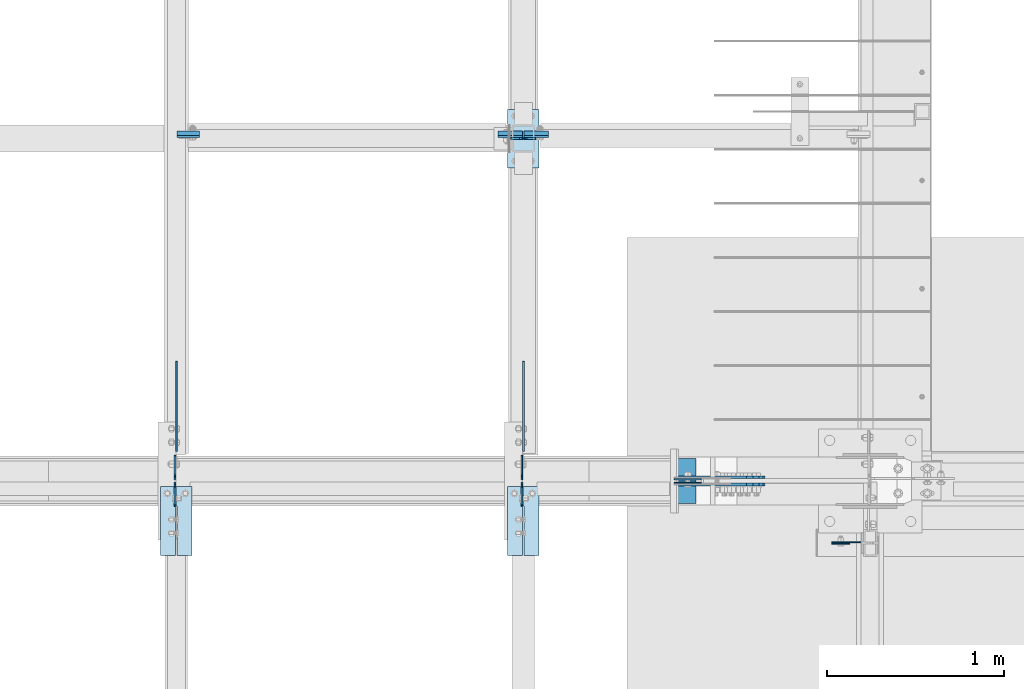
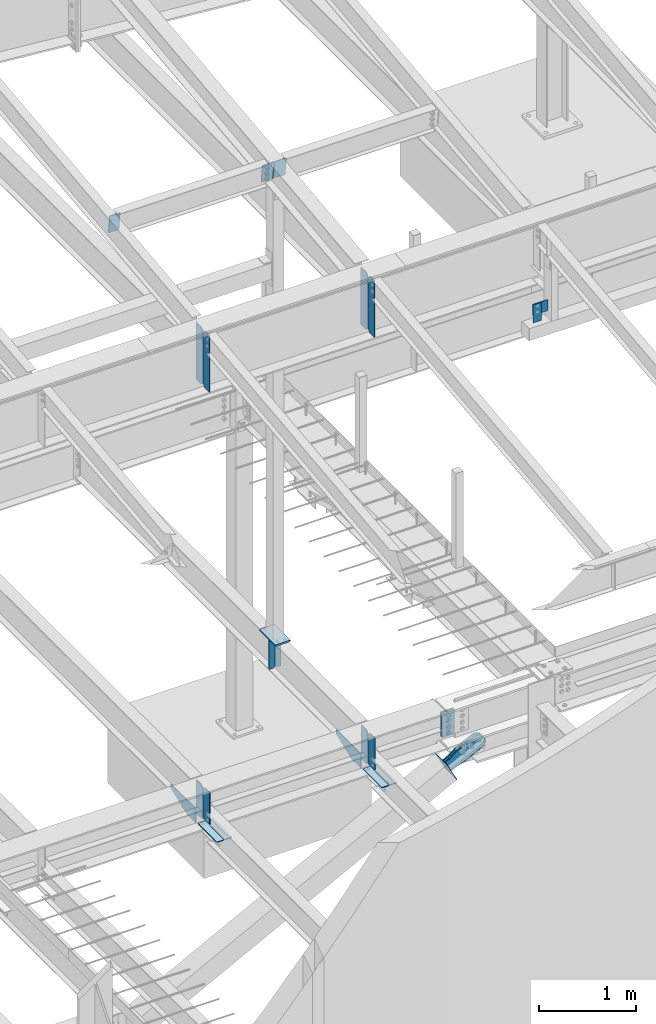
# One storey, part 987 of 1179: 25 plates, 14 elements without a shape of their own.
"""IFC2X3 building model written with IfcOpenShell, lengths in millimetres."""

from ifc_helpers import new_model, si_unit, frame, origin_with_axes, place, context, subcontext, project, spatial, faceted_brep, material, type_object, element, aggregate, save


model = new_model("IFC2X3")

# Units and contexts
model_context = context("Model", 3, precision=1e-05, world=origin_with_axes())
body_context = subcontext(model_context, "Body", "Model", "MODEL_VIEW")
ifc_project = project(units=[si_unit("LENGTHUNIT", "METRE", prefix="MILLI"), si_unit("AREAUNIT", "SQUARE_METRE"), si_unit("VOLUMEUNIT", "CUBIC_METRE"), si_unit("MASSUNIT", "GRAM", prefix="KILO"), si_unit("TIMEUNIT", "SECOND"), si_unit("PLANEANGLEUNIT", "RADIAN"), si_unit("SOLIDANGLEUNIT", "STERADIAN"), si_unit("THERMODYNAMICTEMPERATUREUNIT", "DEGREE_CELSIUS"), si_unit("LUMINOUSINTENSITYUNIT", "LUMEN")], contexts=[model_context])

# Site, building, storey
site_placement = place(None, origin_with_axes())
site = spatial("IfcSite", under=ifc_project, at=site_placement, CompositionType="ELEMENT")
building_placement = place(site_placement, origin_with_axes())
building = spatial("IfcBuilding", under=site, at=building_placement, Name="Undefined", CompositionType="ELEMENT")
storey_placement = place(building_placement, origin_with_axes())
storey = spatial("IfcBuildingStorey", under=building, at=storey_placement, Name="Undefined", CompositionType="ELEMENT", Elevation=0.0)

# Assembly, plates
assembly_1_placement = place(storey_placement, origin_with_axes())
assembly_1 = element("IfcElementAssembly", 1, at=assembly_1_placement, inside=storey, Name="BEAM", AssemblyPlace="NOTDEFINED", PredefinedType="RIGID_FRAME")
ifc_material_1 = material(Name="STEEL/A36")
plate_type_1 = type_object("IfcPlateType", PredefinedType="NOTDEFINED")
plate_1_placement = place(assembly_1_placement, frame((6317.45575008393, 5429.25933465636, 9095.0787842795), z_axis=(0.0, 0.0, 1.0), x_axis=(0.0, -1.0, 0.0)))
plate_1 = element("IfcPlate", 2, at=plate_1_placement, type_object=plate_type_1, material=ifc_material_1, Name="PLATE", context=body_context, shape_type="Brep", body=[
    faceted_brep([(1.81898940354586e-12, -4.76249999999709, 31.75), (0.0, -4.76249999999982, 682.625), (0.0, 4.76249999999982, 682.625), (-1.81898940354586e-12, 4.76249999998981, 31.75), (31.75, -4.76249999999982, 714.375), (31.75, 4.76249999999982, 714.375), (127.0, -4.76249999999982, 714.375), (127.0, 4.76249999999982, 714.375), (127.0, -4.76250000000073, 0.0), (127.0, 4.76250000000073, 0.0), (31.7499999988213, -4.76250000001164, 0.0), (31.7499999988249, 4.76249999998254, 0.0)], [[[0, 1, 2, 3]], [[1, 4, 5, 2]], [[4, 6, 7, 5]], [[6, 8, 9, 7]], [[8, 10, 11, 9]], [[10, 0, 3, 11]], [[5, 7, 9, 11, 3, 2]], [[10, 8, 6, 4, 1, 0]]]),
])
plate_2_placement = place(assembly_1_placement, frame((4361.65575008401, 5429.1855605538, 9095.0787842795), z_axis=(0.0, 0.0, 1.0), x_axis=(0.0, -1.0, 0.0)))
plate_2 = element("IfcPlate", 3, at=plate_2_placement, type_object=plate_type_1, material=ifc_material_1, Name="PLATE", context=body_context, shape_type="Brep", body=[
    faceted_brep([(1.81898940354586e-12, -4.76249999999709, 31.75), (0.0, -4.76249999999982, 682.625), (0.0, 4.76249999999982, 682.625), (-1.81898940354586e-12, 4.76249999998981, 31.75), (31.75, -4.76249999999982, 714.375), (31.75, 4.76249999999982, 714.375), (127.0, -4.76249999999982, 714.375), (127.0, 4.76249999999982, 714.375), (127.0, -4.76250000000073, 0.0), (127.0, 4.76250000000073, 0.0), (31.7499999988213, -4.76250000001164, 0.0), (31.7499999988249, 4.76249999998254, 0.0)], [[[0, 1, 2, 3]], [[1, 4, 5, 2]], [[4, 6, 7, 5]], [[6, 8, 9, 7]], [[8, 10, 11, 9]], [[10, 0, 3, 11]], [[5, 7, 9, 11, 3, 2]], [[10, 8, 6, 4, 1, 0]]]),
])

# Assembly, plate
assembly_2_placement = place(storey_placement, origin_with_axes())
assembly_2 = element("IfcElementAssembly", 4, at=assembly_2_placement, inside=storey, Name="BEAM", AssemblyPlace="NOTDEFINED", PredefinedType="RIGID_FRAME")
plate_3_placement = place(assembly_2_placement, frame((4371.18125, 7377.33420625224, 10042.1704055753), z_axis=(1.0, 0.0, 0.0), x_axis=(0.0, 0.112804359038609, -0.993617218340085)))
plate_3 = element("IfcPlate", 5, at=plate_3_placement, type_object=plate_type_1, material=ifc_material_1, Name="PLATE", context=body_context, shape_type="Brep", body=[
    faceted_brep([(0.0, -4.76249999999709, 0.0), (0.0, -4.76249999999709, 127.0), (0.0, 4.76249999999709, 127.0), (0.0, 4.76249999999709, 0.0), (228.6, -4.76249999999709, 127.0), (228.6, 4.76249999999709, 127.0), (228.6, -4.76249999999709, 0.0), (228.6, 4.76249999999709, 0.0)], [[[0, 1, 2, 3]], [[1, 4, 5, 2]], [[4, 6, 7, 5]], [[6, 0, 3, 7]], [[5, 7, 3, 2]], [[6, 4, 1, 0]]]),
])
aggregate(assembly_2, [plate_3])

assembly_3_placement = place(storey_placement, origin_with_axes())
assembly_3 = element("IfcElementAssembly", 6, at=assembly_3_placement, inside=storey, Name="COLUMN", AssemblyPlace="NOTDEFINED", PredefinedType="RIGID_FRAME")
plate_type_2 = type_object("IfcPlateType", PredefinedType="NOTDEFINED")
plate_4_placement = place(assembly_3_placement, frame((8064.5, 5089.525, 9029.7), z_axis=(1.0, 0.0, 0.0), x_axis=(0.0, 0.0, -1.0)))
plate_4 = element("IfcPlate", 7, at=plate_4_placement, type_object=plate_type_2, material=ifc_material_1, Name="PLATE", context=body_context, shape_type="Brep", body=[
    faceted_brep([(0.0, -3.17500000000109, 0.0), (0.0, -3.17500000000018, 177.800000000003), (0.0, 3.17500000000018, 177.800000000003), (0.0, 3.17500000000109, 7.27595761418343e-12), (139.699996948242, -3.17500000000018, 177.800000000003), (139.699996948242, 3.17500000000018, 177.800000000003), (139.699996948242, -3.17500000000018, 0.0), (139.699996948242, 3.17500000000018, 0.0)], [[[0, 1, 2, 3]], [[1, 4, 5, 2]], [[4, 6, 7, 5]], [[6, 0, 3, 7]], [[5, 7, 3, 2]], [[6, 4, 1, 0]]]),
])
aggregate(assembly_3, [plate_4])

assembly_4_placement = place(storey_placement, origin_with_axes())
assembly_4 = element("IfcElementAssembly", 8, at=assembly_4_placement, inside=storey, Name="BEAM", AssemblyPlace="NOTDEFINED", PredefinedType="RIGID_FRAME")
plate_type_3 = type_object("IfcPlateType", PredefinedType="NOTDEFINED")
plate_5_placement = place(assembly_4_placement, frame((8064.5, 5083.175, 9029.7), z_axis=(1.0, 0.0, 0.0), x_axis=(0.0, 0.0, -1.0)))
plate_5 = element("IfcPlate", 9, at=plate_5_placement, type_object=plate_type_3, material=ifc_material_1, Name="PLATE", context=body_context, shape_type="Brep", body=[
    faceted_brep([(0.0, -3.17500000000109, 0.0), (0.0, -3.17500000000018, 101.599999999999), (0.0, 3.17500000000018, 101.599999999999), (0.0, 3.17500000000109, 7.27595761418343e-12), (228.6, -3.17500000000018, 101.600000000002), (228.6, 3.17500000000018, 101.600000000002), (228.6, -3.17500000000018, 0.0), (228.6, 3.17500000000018, 0.0)], [[[0, 1, 2, 3]], [[1, 4, 5, 2]], [[4, 6, 7, 5]], [[6, 0, 3, 7]], [[5, 7, 3, 2]], [[6, 4, 1, 0]]]),
])
aggregate(assembly_4, [plate_5])

# Assembly, plates
assembly_5_placement = place(storey_placement, origin_with_axes())
assembly_5 = element("IfcElementAssembly", 10, at=assembly_5_placement, inside=storey, Name="BEAM", AssemblyPlace="NOTDEFINED", PredefinedType="RIGID_FRAME")
plate_type_4 = type_object("IfcPlateType", PredefinedType="NOTDEFINED")
plate_6_placement = place(assembly_5_placement, frame((6394.44996446262, 7366.0, 4090.9875), z_axis=(0.0, 0.0, -1.0), x_axis=(-1.0, 0.0, 0.0)))
plate_6 = element("IfcPlate", 11, at=plate_6_placement, type_object=plate_type_4, material=ifc_material_1, Name="PLATE", context=body_context, shape_type="Brep", body=[
    faceted_brep([(0.0, -4.76249999999709, 0.0), (0.0, -4.76249999999982, 381.0), (0.0, 4.76249999999982, 381.0), (0.0, 4.76249999999709, 0.0), (47.6250007629396, -4.76249999999982, 381.0), (47.6250007629396, 4.76249999999982, 381.0), (66.6750000000002, -4.76249999999982, 361.950000762939), (66.6750000000002, 4.76249999999982, 361.950000762939), (66.6750000000002, -4.76249999999982, 19.0499992370605), (66.6750000000002, 4.76249999999982, 19.0499992370605), (47.625, -4.76249999999527, 1.81898940354586e-12), (47.625, 4.76250000000073, 0.0)], [[[0, 1, 2, 3]], [[1, 4, 5, 2]], [[4, 6, 7, 5]], [[6, 8, 9, 7]], [[8, 10, 11, 9]], [[10, 0, 3, 11]], [[5, 7, 9, 11, 3, 2]], [[10, 8, 6, 4, 1, 0]]]),
])
plate_7_placement = place(assembly_5_placement, frame((6254.74996446262, 7366.0, 4090.9875), z_axis=(0.0, 0.0, -1.0), x_axis=(1.0, 0.0, 0.0)))
plate_7 = element("IfcPlate", 12, at=plate_7_placement, type_object=plate_type_4, material=ifc_material_1, Name="PLATE", context=body_context, shape_type="Brep", body=[
    faceted_brep([(0.0, -4.76249999999709, 0.0), (0.0, -4.76249999999982, 381.0), (0.0, 4.76249999999982, 381.0), (0.0, 4.76249999999709, 0.0), (47.6249315497826, -4.76249999999982, 381.0), (47.6249315497826, 4.76249999999982, 381.0), (66.6749307868431, -4.76249999999982, 361.950000762939), (66.6749307868431, 4.76249999999982, 361.950000762939), (66.6749307868431, -4.76249999999982, 19.0499992370605), (66.6749307868431, 4.76249999999982, 19.0499992370605), (47.6249315497826, -4.76249999999982, 0.0), (47.6249315497826, 4.76249999999982, 0.0)], [[[0, 1, 2, 3]], [[1, 4, 5, 2]], [[4, 6, 7, 5]], [[6, 8, 9, 7]], [[8, 10, 11, 9]], [[10, 0, 3, 11]], [[5, 7, 9, 11, 3, 2]], [[10, 8, 6, 4, 1, 0]]]),
])

assembly_6_placement = place(storey_placement, origin_with_axes())
assembly_6 = element("IfcElementAssembly", 13, at=assembly_6_placement, inside=storey, Name="BEAM", AssemblyPlace="NOTDEFINED", PredefinedType="RIGID_FRAME")
plate_type_5 = type_object("IfcPlateType", PredefinedType="NOTDEFINED")
plate_8_placement = place(assembly_6_placement, frame((4360.86207262984, 5441.95000011429, 3656.0125), z_axis=(0.0, 0.0, 1.0), x_axis=(0.0, 1.0, 0.0)))
plate_8 = element("IfcPlate", 14, at=plate_8_placement, type_object=plate_type_5, material=ifc_material_1, Name="PLATE", context=body_context, shape_type="Brep", body=[
    faceted_brep([(0.0, -4.76250000000073, 25.3999996185303), (9.09494701772928e-13, -4.76250000000073, 400.05000038147), (2.72848410531878e-12, 4.76249999999891, 400.05000038147), (0.0, 4.76250000000073, 25.3999996185303), (25.3999996185312, -4.76250000000709, 425.45), (25.399999618533, 4.76249999999254, 425.45), (134.937500000001, -4.76250000003438, 425.45), (134.937500000003, 4.76249999996526, 425.45), (134.937500000001, -4.76250000003438, 0.0), (134.937500000003, 4.76249999996526, 0.0), (25.3999996185303, -4.76250000000073, 0.0), (25.3999996185303, 4.76250000000073, 0.0)], [[[0, 1, 2, 3]], [[1, 4, 5, 2]], [[4, 6, 7, 5]], [[6, 8, 9, 7]], [[8, 10, 11, 9]], [[10, 0, 3, 11]], [[5, 7, 9, 11, 3, 2]], [[10, 8, 6, 4, 1, 0]]]),
])
plate_9_placement = place(assembly_6_placement, frame((4360.86249259372, 5294.3125, 3683.0), z_axis=(0.0, 0.0, 1.0), x_axis=(0.0, 1.0, 0.0)))
plate_9 = element("IfcPlate", 15, at=plate_9_placement, type_object=plate_type_5, material=ifc_material_1, Name="PLATE", context=body_context, shape_type="Brep", body=[
    faceted_brep([(0.0, -4.76249999999709, 0.0), (9.09494701772928e-13, -4.76250000000073, 400.05000038147), (2.72848410531878e-12, 4.76249999999891, 400.05000038147), (0.0, 4.76249999999709, 0.0), (109.53750038147, -4.76249999999982, 400.049987792969), (109.53750038147, 4.76249999999982, 400.049987792969), (134.9375, -4.76249999999982, 374.649988174438), (134.9375, 4.76249999999982, 374.649988174438), (134.937500000001, -4.76250000003438, 0.0), (134.937500000003, 4.76249999996526, 0.0)], [[[0, 1, 2, 3]], [[1, 4, 5, 2]], [[4, 6, 7, 5]], [[6, 8, 9, 7]], [[8, 0, 3, 9]], [[5, 7, 9, 3, 2]], [[8, 6, 4, 1, 0]]]),
])
plate_10_placement = place(assembly_6_placement, frame((6316.66246107175, 5294.3125001905, 3683.0), z_axis=(0.0, 0.0, 1.0), x_axis=(0.0, 1.0, 0.0)))
plate_10 = element("IfcPlate", 16, at=plate_10_placement, type_object=plate_type_5, material=ifc_material_1, Name="PLATE", context=body_context, shape_type="Brep", body=[
    faceted_brep([(0.0, -4.76249999999709, 0.0), (9.09494701772928e-13, -4.76250000000073, 400.05000038147), (2.72848410531878e-12, 4.76249999999891, 400.05000038147), (0.0, 4.76249999999709, 0.0), (109.53750038147, -4.76249999999982, 400.049987792969), (109.53750038147, 4.76249999999982, 400.049987792969), (134.9375, -4.76249999999982, 374.649988174438), (134.9375, 4.76249999999982, 374.649988174438), (134.937500000001, -4.76250000003438, 0.0), (134.937500000003, 4.76249999996526, 0.0)], [[[0, 1, 2, 3]], [[1, 4, 5, 2]], [[4, 6, 7, 5]], [[6, 8, 9, 7]], [[8, 0, 3, 9]], [[5, 7, 9, 3, 2]], [[8, 6, 4, 1, 0]]]),
])
plate_11_placement = place(assembly_6_placement, frame((6316.66196454654, 5441.95, 3656.0125), z_axis=(0.0, 0.0, 1.0), x_axis=(0.0, 1.0, 0.0)))
plate_11 = element("IfcPlate", 17, at=plate_11_placement, type_object=plate_type_5, material=ifc_material_1, Name="PLATE", context=body_context, shape_type="Brep", body=[
    faceted_brep([(0.0, -4.76250000000073, 25.3999996185303), (9.09494701772928e-13, -4.76250000000073, 400.05000038147), (2.72848410531878e-12, 4.76249999999891, 400.05000038147), (0.0, 4.76250000000073, 25.3999996185303), (25.3999996185312, -4.76250000000709, 425.45), (25.399999618533, 4.76249999999254, 425.45), (134.937500000001, -4.76250000003438, 425.45), (134.937500000003, 4.76249999996526, 425.45), (134.937500000001, -4.76250000003438, 0.0), (134.937500000003, 4.76249999996526, 0.0), (25.3999996185303, -4.76250000000073, 0.0), (25.3999996185303, 4.76250000000073, 0.0)], [[[0, 1, 2, 3]], [[1, 4, 5, 2]], [[4, 6, 7, 5]], [[6, 8, 9, 7]], [[8, 10, 11, 9]], [[10, 0, 3, 11]], [[5, 7, 9, 11, 3, 2]], [[10, 8, 6, 4, 1, 0]]]),
])

# Plate
plate_type_6 = type_object("IfcPlateType", PredefinedType="NOTDEFINED")
plate_12_placement = place(assembly_1_placement, frame((6316.66200008393, 5441.95933465636, 9095.0787842795), z_axis=(0.0, 0.0, 1.0), x_axis=(0.0, 1.0, 0.0)))
plate_12 = element("IfcPlate", 18, at=plate_12_placement, type_object=plate_type_6, material=ifc_material_1, Name="PLATE", context=body_context, shape_type="Brep", body=[
    faceted_brep([(1.81898940354586e-12, -4.76249999999709, 31.75), (0.0, -4.76249999999982, 682.625), (0.0, 4.76249999999982, 682.625), (-1.81898940354586e-12, 4.76249999998981, 31.75), (31.75, -4.76249999999982, 714.375), (31.75, 4.76249999999982, 714.375), (139.7, -4.76249999999982, 714.375), (139.7, 4.76249999999982, 714.375), (139.7, -4.76249999999982, 0.0), (139.7, 4.76249999999982, 0.0), (31.7499999988213, -4.76250000001164, 0.0), (31.7499999988249, 4.76249999998254, 0.0)], [[[0, 1, 2, 3]], [[1, 4, 5, 2]], [[4, 6, 7, 5]], [[6, 8, 9, 7]], [[8, 10, 11, 9]], [[10, 0, 3, 11]], [[5, 7, 9, 11, 3, 2]], [[10, 8, 6, 4, 1, 0]]]),
])

plate_13_placement = place(assembly_1_placement, frame((4361.65575008401, 5441.88573914977, 9095.0787842795), z_axis=(0.0, 0.0, 1.0), x_axis=(0.0, 1.0, 0.0)))
plate_13 = element("IfcPlate", 19, at=plate_13_placement, type_object=plate_type_6, material=ifc_material_1, Name="PLATE", context=body_context, shape_type="Brep", body=[
    faceted_brep([(1.81898940354586e-12, -4.76249999999709, 31.75), (0.0, -4.76249999999982, 682.625), (0.0, 4.76249999999982, 682.625), (-1.81898940354586e-12, 4.76249999998981, 31.75), (31.75, -4.76249999999982, 714.375), (31.75, 4.76249999999982, 714.375), (139.7, -4.76249999999982, 714.375), (139.7, 4.76249999999982, 714.375), (139.7, -4.76249999999982, 0.0), (139.7, 4.76249999999982, 0.0), (31.7499999988213, -4.76250000001164, 0.0), (31.7499999988249, 4.76249999998254, 0.0)], [[[0, 1, 2, 3]], [[1, 4, 5, 2]], [[4, 6, 7, 5]], [[6, 8, 9, 7]], [[8, 10, 11, 9]], [[10, 0, 3, 11]], [[5, 7, 9, 11, 3, 2]], [[10, 8, 6, 4, 1, 0]]]),
])

aggregate(assembly_1, [plate_12, plate_1, plate_2, plate_13])

# Assembly, plates
assembly_7_placement = place(storey_placement, origin_with_axes())
assembly_7 = element("IfcElementAssembly", 20, at=assembly_7_placement, inside=storey, Name="BEAM", AssemblyPlace="NOTDEFINED", PredefinedType="RIGID_FRAME")
plate_14_placement = place(assembly_7_placement, frame((6321.425, 7377.33420625226, 10042.170405575), z_axis=(-1.0, 0.0, 0.0), x_axis=(0.0, 0.112804359038609, -0.993617218340085)))
plate_14 = element("IfcPlate", 21, at=plate_14_placement, type_object=plate_type_6, material=ifc_material_1, Name="PLATE", context=body_context, shape_type="Brep", body=[
    faceted_brep([(0.0, -4.76249999999709, 0.0), (0.0, -4.76249999999982, 139.699999999997), (0.0, 4.76249999999982, 139.699999999997), (0.0, 4.76249999999709, 0.0), (228.600000000459, -4.76250000003165, 139.7), (228.600000000453, 4.76249999996617, 139.7), (228.6, -4.76249999999709, 0.0), (228.6, 4.76249999999709, 0.0)], [[[0, 1, 2, 3]], [[1, 4, 5, 2]], [[4, 6, 7, 5]], [[6, 0, 3, 7]], [[5, 7, 3, 2]], [[6, 4, 1, 0]]]),
])
plate_15_placement = place(assembly_7_placement, frame((6327.775, 7377.33420625225, 10042.170405575), z_axis=(1.0, 0.0, 0.0), x_axis=(0.0, 0.112804359038609, -0.993617218340085)))
plate_15 = element("IfcPlate", 22, at=plate_15_placement, type_object=plate_type_6, material=ifc_material_1, Name="PLATE", context=body_context, shape_type="Brep", body=[
    faceted_brep([(0.0, -4.76249999999709, 0.0), (0.0, -4.76249999999982, 139.699999999997), (0.0, 4.76249999999982, 139.699999999997), (0.0, 4.76249999999709, 0.0), (228.600000000459, -4.76250000003165, 139.7), (228.600000000453, 4.76249999996617, 139.7), (228.6, -4.76249999999709, 0.0), (228.6, 4.76249999999709, 0.0)], [[[0, 1, 2, 3]], [[1, 4, 5, 2]], [[4, 6, 7, 5]], [[6, 0, 3, 7]], [[5, 7, 3, 2]], [[6, 4, 1, 0]]]),
])
aggregate(assembly_7, [plate_14, plate_15])

# Assembly, plate
assembly_8_placement = place(storey_placement, origin_with_axes())
assembly_8 = element("IfcElementAssembly", 23, at=assembly_8_placement, inside=storey, Name="COLUMN", AssemblyPlace="NOTDEFINED", PredefinedType="RIGID_FRAME")
plate_type_7 = type_object("IfcPlateType", PredefinedType="NOTDEFINED")
plate_16_placement = place(assembly_8_placement, frame((6235.69996446262, 7200.9, 4111.625), z_axis=(0.0, 1.0, 0.0), x_axis=(1.0, 0.0, 0.0)))
plate_16 = element("IfcPlate", 24, at=plate_16_placement, type_object=plate_type_7, material=ifc_material_1, Name="PLATE", context=body_context, shape_type="Brep", body=[
    faceted_brep([(0.0, -9.52499999999964, 0.0), (0.0, -9.52499999999964, 330.200012207031), (0.0, 9.52499999999964, 330.200012207031), (0.0, 9.52499999999964, 0.0), (177.800003051758, -9.52499999999964, 330.200012207031), (177.800003051758, 9.52499999999964, 330.200012207031), (177.800003051758, -9.52499999999964, 0.0), (177.800003051758, 9.52499999999964, 0.0)], [[[0, 1, 2, 3]], [[1, 4, 5, 2]], [[4, 6, 7, 5]], [[6, 0, 3, 7]], [[5, 7, 3, 2]], [[6, 4, 1, 0]]]),
])
aggregate(assembly_8, [plate_16])

assembly_9_placement = place(storey_placement, origin_with_axes())
assembly_9 = element("IfcElementAssembly", 25, at=assembly_9_placement, inside=storey, Name="BEAM", AssemblyPlace="NOTDEFINED", PredefinedType="RIGID_FRAME")
plate_type_8 = type_object("IfcPlateType", PredefinedType="NOTDEFINED")
plate_17_placement = place(assembly_9_placement, frame((4370.3870859597, 5602.28735337109, 3698.875), z_axis=(0.0, 1.0, 0.0), x_axis=(0.0, 0.0, -1.0)))
plate_17 = element("IfcPlate", 26, at=plate_17_placement, type_object=plate_type_8, material=ifc_material_1, Name="PLATE", context=body_context, shape_type="Brep", body=[
    faceted_brep([(0.0, -4.76249999999709, 0.0), (0.0, -4.76249999999982, 508.0), (0.0, 4.76249999999982, 508.0), (0.0, 4.76249999999709, 0.0), (50.7999992370605, -4.76249999999982, 508.0), (50.7999992370605, 4.76249999999982, 508.0), (177.800003051758, -4.76249999999982, 190.5), (177.800003051758, 4.76249999999982, 190.5), (177.800003051758, -4.76249999999982, 0.0), (177.800003051758, 4.76249999999982, 0.0)], [[[0, 1, 2, 3]], [[1, 4, 5, 2]], [[4, 6, 7, 5]], [[6, 8, 9, 7]], [[8, 0, 3, 9]], [[5, 7, 9, 3, 2]], [[8, 6, 4, 1, 0]]]),
])
aggregate(assembly_9, [plate_17])

assembly_10_placement = place(storey_placement, origin_with_axes())
assembly_10 = element("IfcElementAssembly", 27, at=assembly_10_placement, inside=storey, Name="BEAM", AssemblyPlace="NOTDEFINED", PredefinedType="RIGID_FRAME")
plate_18_placement = place(assembly_10_placement, frame((4457.69999259373, 5403.85000000985, 3659.1875), z_axis=(0.0, -1.0, 0.0), x_axis=(-1.0, 0.0, 0.0)))
plate_18 = element("IfcPlate", 28, at=plate_18_placement, type_object=plate_type_8, material=ifc_material_1, Name="PLATE", context=body_context, shape_type="Brep", body=[
    faceted_brep([(84.1374995016549, -4.76249999999982, 388.937506103519), (84.1374997809262, -4.76249999999982, 109.537497498053), (84.1374997809262, 4.76249999999982, 109.537497498053), (84.1374995016549, 4.76249999999982, 388.937506103519), (93.6624993994565, -4.76249999999982, 109.537497513039), (93.6624993994565, 4.76249999999982, 109.537497513039), (93.6624981665036, -4.76249999999982, 388.93749748426), (93.6624981665036, 4.76249999999982, 388.937506103519), (0.0, -4.76249999999709, 0.0), (-1.46801176015288e-06, -4.76249999999982, 388.937506103516), (-1.46801176015288e-06, 4.76249999999982, 388.937506103516), (0.0, 4.76249999999709, 0.0), (177.800003051758, -4.76249999999982, 0.0), (177.800003051758, 4.76249999999982, 0.0), (177.799987132177, -4.76249999999982, 388.937506103521), (177.799987132177, 4.76249999999982, 388.937506103521)], [[[0, 1, 2, 3]], [[4, 5, 2, 1]], [[6, 7, 5, 4]], [[8, 9, 10, 11]], [[12, 8, 11, 13]], [[14, 12, 13, 15]], [[1, 0, 9, 8, 12, 14, 6, 4]], [[10, 9, 0, 3]], [[15, 13, 11, 10, 3, 2, 5, 7]], [[14, 15, 7, 6]]]),
])
aggregate(assembly_10, [plate_18])

# Plate
plate_19_placement = place(assembly_5_placement, frame((6326.18697575612, 5602.28749996191, 3698.875), z_axis=(0.0, 1.0, 0.0), x_axis=(0.0, 0.0, -1.0)))
plate_19 = element("IfcPlate", 29, at=plate_19_placement, type_object=plate_type_8, material=ifc_material_1, Name="PLATE", context=body_context, shape_type="Brep", body=[
    faceted_brep([(0.0, -4.76249999999709, 0.0), (0.0, -4.76249999999982, 508.0), (0.0, 4.76249999999982, 508.0), (0.0, 4.76249999999709, 0.0), (50.7999992370605, -4.76249999999982, 508.0), (50.7999992370605, 4.76249999999982, 508.0), (177.800003051758, -4.76249999999982, 190.5), (177.800003051758, 4.76249999999982, 190.5), (177.800003051758, -4.76249999999982, 0.0), (177.800003051758, 4.76249999999982, 0.0)], [[[0, 1, 2, 3]], [[1, 4, 5, 2]], [[4, 6, 7, 5]], [[6, 8, 9, 7]], [[8, 0, 3, 9]], [[5, 7, 9, 3, 2]], [[8, 6, 4, 1, 0]]]),
])

aggregate(assembly_5, [plate_6, plate_7, plate_19])

# Assembly, plate
assembly_11_placement = place(storey_placement, origin_with_axes())
assembly_11 = element("IfcElementAssembly", 30, at=assembly_11_placement, inside=storey, Name="BEAM", AssemblyPlace="NOTDEFINED", PredefinedType="RIGID_FRAME")
plate_20_placement = place(assembly_11_placement, frame((6413.49996370062, 5403.84999786638, 3659.1875), z_axis=(0.0, -1.0, 0.0), x_axis=(-1.0, 0.0, 0.0)))
plate_20 = element("IfcPlate", 31, at=plate_20_placement, type_object=plate_type_8, material=ifc_material_1, Name="PLATE", context=body_context, shape_type="Brep", body=[
    faceted_brep([(84.1374995016549, -4.76249999999982, 388.937506103519), (84.1374997809262, -4.76249999999982, 109.537497498053), (84.1374997809262, 4.76249999999982, 109.537497498053), (84.1374995016549, 4.76249999999982, 388.937506103519), (93.6624993994565, -4.76249999999982, 109.537497513039), (93.6624993994565, 4.76249999999982, 109.537497513039), (93.6624981665036, -4.76249999999982, 388.93749748426), (93.6624981665036, 4.76249999999982, 388.937506103519), (0.0, -4.76249999999709, 0.0), (-1.46801176015288e-06, -4.76249999999982, 388.937506103516), (-1.46801176015288e-06, 4.76249999999982, 388.937506103516), (0.0, 4.76249999999709, 0.0), (177.800003051758, -4.76249999999982, 0.0), (177.800003051758, 4.76249999999982, 0.0), (177.799987132177, -4.76249999999982, 388.937506103521), (177.799987132177, 4.76249999999982, 388.937506103521)], [[[0, 1, 2, 3]], [[4, 5, 2, 1]], [[6, 7, 5, 4]], [[8, 9, 10, 11]], [[12, 8, 11, 13]], [[14, 12, 13, 15]], [[1, 0, 9, 8, 12, 14, 6, 4]], [[10, 9, 0, 3]], [[15, 13, 11, 10, 3, 2, 5, 7]], [[14, 15, 7, 6]]]),
])
aggregate(assembly_11, [plate_20])

# Plate
ifc_material_2 = material(Name="STEEL/A572-GR.50")
plate_type_9 = type_object("IfcPlateType", PredefinedType="NOTDEFINED")
plate_21_placement = place(assembly_6_placement, frame((7328.2030421311, 5426.075, 4021.1375), z_axis=(0.0, 0.0, -1.0), x_axis=(-1.0, 0.0, 0.0)))
plate_21 = element("IfcPlate", 32, at=plate_21_placement, type_object=plate_type_9, material=ifc_material_2, Name="PLATE", context=body_context, shape_type="Brep", body=[
    faceted_brep([(0.0, -3.17500000000109, 0.0), (0.0, -3.17500000000018, 304.8), (0.0, 3.17500000000018, 304.8), (0.0, 3.17500000000109, 7.27595761418343e-12), (152.400000000001, -3.17500000000018, 304.8), (152.400000000001, 3.17500000000018, 304.8), (152.400000000001, -3.17500000000018, 0.0), (152.400000000001, 3.17500000000018, 0.0)], [[[0, 1, 2, 3]], [[1, 4, 5, 2]], [[4, 6, 7, 5]], [[6, 0, 3, 7]], [[5, 7, 3, 2]], [[6, 4, 1, 0]]]),
])

plate_22_placement = place(assembly_6_placement, frame((7328.2030421311, 5445.125, 4021.1375), z_axis=(0.0, 0.0, -1.0), x_axis=(-1.0, 0.0, 0.0)))
plate_22 = element("IfcPlate", 33, at=plate_22_placement, type_object=plate_type_9, material=ifc_material_2, Name="PLATE", context=body_context, shape_type="Brep", body=[
    faceted_brep([(0.0, -3.17500000000109, 0.0), (0.0, -3.17500000000018, 304.8), (0.0, 3.17500000000018, 304.8), (0.0, 3.17500000000109, 7.27595761418343e-12), (152.400000000001, -3.17500000000018, 304.8), (152.400000000001, 3.17500000000018, 304.8), (152.400000000001, -3.17500000000018, 0.0), (152.400000000001, 3.17500000000018, 0.0)], [[[0, 1, 2, 3]], [[1, 4, 5, 2]], [[4, 6, 7, 5]], [[6, 0, 3, 7]], [[5, 7, 3, 2]], [[6, 4, 1, 0]]]),
])

aggregate(assembly_6, [plate_21, plate_22, plate_8, plate_9, plate_10, plate_11])

# Assembly, plate
assembly_12_placement = place(storey_placement, origin_with_axes())
assembly_12 = element("IfcElementAssembly", 34, at=assembly_12_placement, inside=storey, Name="Plate", AssemblyPlace="NOTDEFINED", PredefinedType="RIGID_FRAME")
plate_type_10 = type_object("IfcPlateType", PredefinedType="NOTDEFINED")
plate_23_placement = place(assembly_12_placement, frame((7294.6953167231, 5308.6, 3212.57898711208), z_axis=(-0.461652125829643, 0.0, 0.88706105467266), x_axis=(0.0, 1.0, 0.0)))
plate_23 = element("IfcPlate", 35, at=plate_23_placement, type_object=plate_type_10, material=ifc_material_1, Name="Plate", context=body_context, shape_type="Brep", body=[
    faceted_brep([(0.0, -3.17500000000109, 0.0), (0.0, -3.17499999986103, 253.99999999967), (0.0, 3.17500000013752, 253.999999999668), (0.0, 3.17500000000109, 7.27595761418343e-12), (254.0, -3.17499999986103, 253.99999999967), (254.0, 3.17500000013752, 253.999999999668), (254.0, -3.17500000000109, 9.09494701772928e-13), (254.0, 3.17499999999745, -1.36424205265939e-12)], [[[0, 1, 2, 3]], [[1, 4, 5, 2]], [[4, 6, 7, 5]], [[6, 0, 3, 7]], [[5, 7, 3, 2]], [[6, 4, 1, 0]]]),
])
aggregate(assembly_12, [plate_23])

assembly_13_placement = place(storey_placement, origin_with_axes())
assembly_13 = element("IfcElementAssembly", 36, at=assembly_13_placement, inside=storey, AssemblyPlace="NOTDEFINED", PredefinedType="RIGID_FRAME")
plate_type_11 = type_object("IfcPlateType", PredefinedType="NOTDEFINED")
plate_24_placement = place(assembly_13_placement, frame((7267.15854380592, 5456.2375, 3258.61321426478), z_axis=(-0.461652125829643, 0.0, 0.88706105467266), x_axis=(0.88706105467266, 0.0, 0.461652125829643)))
plate_24 = element("IfcPlate", 37, at=plate_24_placement, type_object=plate_type_11, material=ifc_material_1, context=body_context, shape_type="Brep", body=[
    faceted_brep([(0.0, -7.9375, 0.0), (-8.00355337560177e-11, -7.9375, 146.904840309817), (-8.00355337560177e-11, 7.9375, 146.904840309817), (0.0, 7.9375, 0.0), (82.5499999998137, -7.9375, 146.90484031055), (82.5499999998137, 7.9375, 146.90484031055), (184.150000000214, -7.9375, 168.702420155054), (184.150000000214, 7.9375, 168.702420155054), (403.471138850085, -7.9375, 168.70242015493), (403.471138850085, 7.9375, 168.70242015493), (439.921735782846, -7.9375, 161.451945626626), (439.921735782846, 7.9375, 161.451945626626), (470.823059758064, -7.9375, 140.804341062974), (470.823059758064, 7.9375, 140.804341062974), (491.470664321725, -7.9375, 109.903017087783), (491.470664321725, 7.9375, 109.903017087783), (498.721138850011, -7.9375, 73.4524201549993), (498.721138850011, 7.9375, 73.4524201549993), (491.470664321694, -7.9375, 37.001823222241), (491.470664321694, 7.9375, 37.001823222241), (470.82305975797, -7.9375, 6.10049924700979), (470.82305975797, 7.9375, 6.10049924700979), (439.921735782676, -7.9375, -14.5471053166548), (439.921735782676, 7.9375, -14.5471053166548), (403.471138849898, -7.9375, -21.7975798449352), (403.471138849898, 7.9375, -21.7975798449352), (184.150000000169, -7.9375, -21.7975798448115), (184.150000000169, 7.9375, -21.7975798448115), (82.5500000000975, -7.9375, -6.91215973347425e-11), (82.5500000000975, 7.9375, -6.91215973347425e-11)], [[[0, 1, 2, 3]], [[1, 4, 5, 2]], [[4, 6, 7, 5]], [[6, 8, 9, 7]], [[8, 10, 11, 9]], [[10, 12, 13, 11]], [[12, 14, 15, 13]], [[14, 16, 17, 15]], [[16, 18, 19, 17]], [[18, 20, 21, 19]], [[20, 22, 23, 21]], [[22, 24, 25, 23]], [[24, 26, 27, 25]], [[26, 28, 29, 27]], [[28, 0, 3, 29]], [[5, 7, 9, 11, 13, 15, 17, 19, 21, 23, 25, 27, 29, 3, 2]], [[28, 26, 24, 22, 20, 18, 16, 14, 12, 10, 8, 6, 4, 1, 0]]]),
])
aggregate(assembly_13, [plate_24])

assembly_14_placement = place(storey_placement, origin_with_axes())
assembly_14 = element("IfcElementAssembly", 38, at=assembly_14_placement, inside=storey, AssemblyPlace="NOTDEFINED", PredefinedType="RIGID_FRAME")
plate_25_placement = place(assembly_14_placement, frame((7267.15854380592, 5414.9625, 3258.61321426478), z_axis=(-0.461652125829643, 0.0, 0.88706105467266), x_axis=(0.88706105467266, 0.0, 0.461652125829643)))
plate_25 = element("IfcPlate", 39, at=plate_25_placement, type_object=plate_type_11, material=ifc_material_1, context=body_context, shape_type="Brep", body=[
    faceted_brep([(0.0, -7.9375, 0.0), (-8.00355337560177e-11, -7.9375, 146.904840309817), (-8.00355337560177e-11, 7.9375, 146.904840309817), (0.0, 7.9375, 0.0), (82.5499999998137, -7.9375, 146.90484031055), (82.5499999998137, 7.9375, 146.90484031055), (184.150000000214, -7.9375, 168.702420155054), (184.150000000214, 7.9375, 168.702420155054), (403.471138850085, -7.9375, 168.70242015493), (403.471138850085, 7.9375, 168.70242015493), (439.921735782846, -7.9375, 161.451945626626), (439.921735782846, 7.9375, 161.451945626626), (470.823059758064, -7.9375, 140.804341062974), (470.823059758064, 7.9375, 140.804341062974), (491.470664321725, -7.9375, 109.903017087783), (491.470664321725, 7.9375, 109.903017087783), (498.721138850011, -7.9375, 73.4524201549993), (498.721138850011, 7.9375, 73.4524201549993), (491.470664321694, -7.9375, 37.001823222241), (491.470664321694, 7.9375, 37.001823222241), (470.82305975797, -7.9375, 6.10049924700979), (470.82305975797, 7.9375, 6.10049924700979), (439.921735782676, -7.9375, -14.5471053166548), (439.921735782676, 7.9375, -14.5471053166548), (403.471138849898, -7.9375, -21.7975798449352), (403.471138849898, 7.9375, -21.7975798449352), (184.150000000169, -7.9375, -21.7975798448115), (184.150000000169, 7.9375, -21.7975798448115), (82.5500000000975, -7.9375, -6.91215973347425e-11), (82.5500000000975, 7.9375, -6.91215973347425e-11)], [[[0, 1, 2, 3]], [[1, 4, 5, 2]], [[4, 6, 7, 5]], [[6, 8, 9, 7]], [[8, 10, 11, 9]], [[10, 12, 13, 11]], [[12, 14, 15, 13]], [[14, 16, 17, 15]], [[16, 18, 19, 17]], [[18, 20, 21, 19]], [[20, 22, 23, 21]], [[22, 24, 25, 23]], [[24, 26, 27, 25]], [[26, 28, 29, 27]], [[28, 0, 3, 29]], [[5, 7, 9, 11, 13, 15, 17, 19, 21, 23, 25, 27, 29, 3, 2]], [[28, 26, 24, 22, 20, 18, 16, 14, 12, 10, 8, 6, 4, 1, 0]]]),
])
aggregate(assembly_14, [plate_25])

save(model, "model.ifc")
